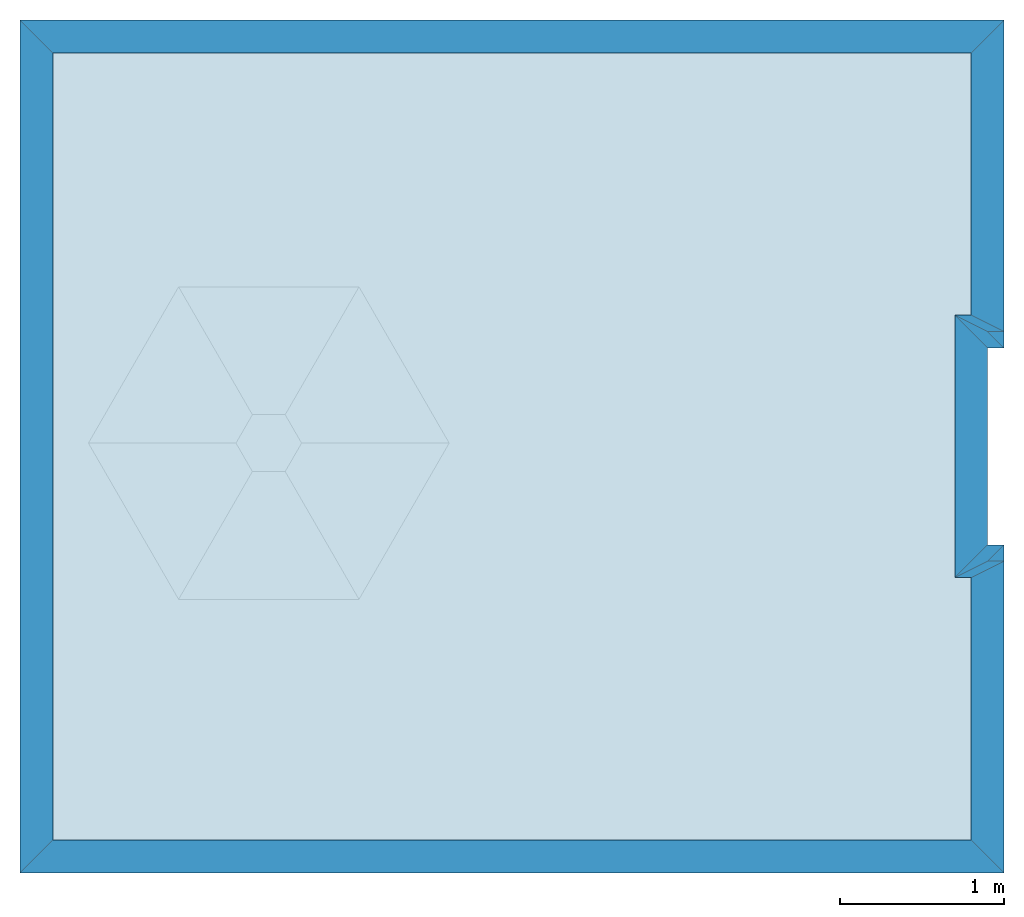
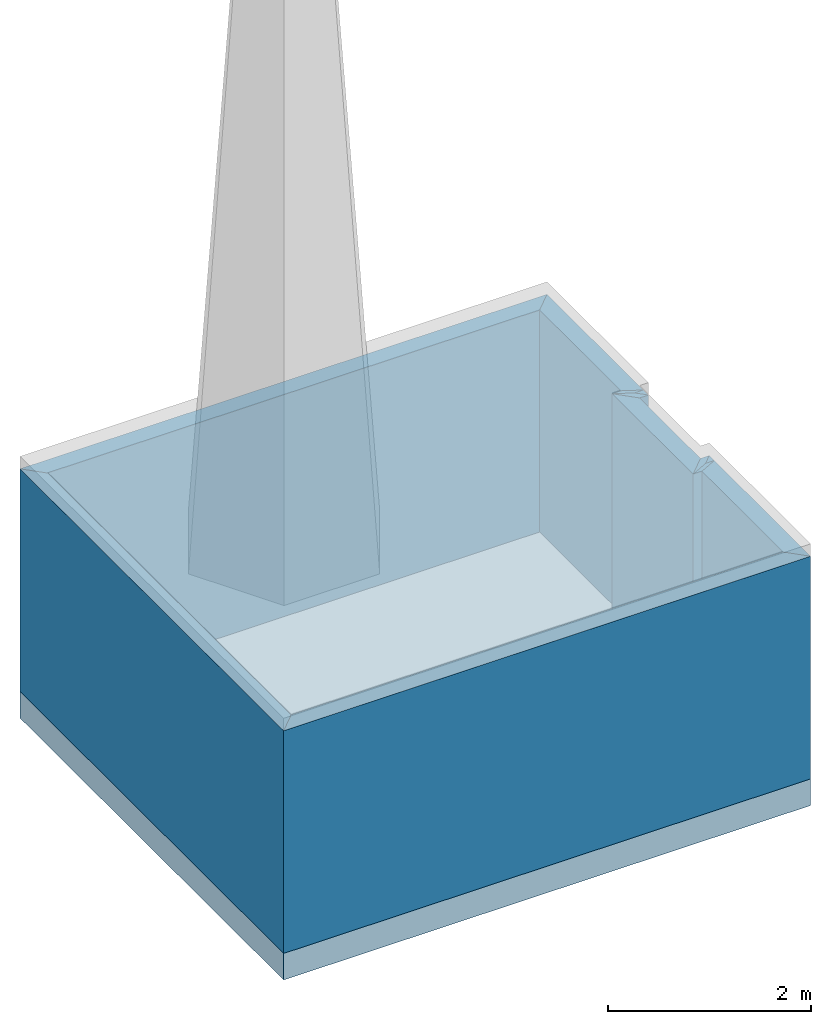
# One storey, part 1 of 2: 10 walls, 3 slabs.
"""IFC2X3 building model written with IfcOpenShell, lengths in metres."""

from ifc_helpers import new_model, entity, si_unit, converted_unit, derived_unit, frame, origin_with_axes, place, context, project, spatial, polyline, outline, extrude, material, layer, layer_set, layer_usage, element, save


model = new_model("IFC2X3")

# Units and contexts
context_of_model_1 = context(None, 3, world=origin_with_axes())
context_of_model_2 = context(None, 3, world=origin_with_axes())
context_of_model_3 = context(None, 2, world=origin_with_axes())
context_of_model_4 = context(None, 3, world=origin_with_axes())
ifc_project = project(units=[si_unit("LENGTHUNIT", "METRE"), si_unit("AREAUNIT", "SQUARE_METRE"), si_unit("ELECTRICCURRENTUNIT", "AMPERE"), si_unit("ELECTRICVOLTAGEUNIT", "VOLT"), si_unit("ELECTRICRESISTANCEUNIT", "OHM"), si_unit("POWERUNIT", "WATT"), si_unit("MASSUNIT", "GRAM"), si_unit("SOLIDANGLEUNIT", "STERADIAN"), si_unit("THERMODYNAMICTEMPERATUREUNIT", "KELVIN"), si_unit("PRESSUREUNIT", "PASCAL"), si_unit("LUMINOUSFLUXUNIT", "LUMEN"), si_unit("ILLUMINANCEUNIT", "LUX"), si_unit("FREQUENCYUNIT", "HERTZ"), si_unit("VOLUMEUNIT", "CUBIC_METRE"), si_unit("TIMEUNIT", "SECOND"), derived_unit("VOLUMETRICFLOWRATEUNIT", [(si_unit("TIMEUNIT", "SECOND"), -1), (si_unit("VOLUMEUNIT", "CUBIC_METRE"), 1)]), derived_unit("THERMALTRANSMITTANCEUNIT", [(si_unit("AREAUNIT", "SQUARE_METRE"), -1), (si_unit("THERMODYNAMICTEMPERATUREUNIT", "KELVIN"), -1), (si_unit("POWERUNIT", "WATT"), 1)]), converted_unit("PLANEANGLEUNIT", "DEGREE", entity("IfcPlaneAngleMeasure", 57.29577951308232), si_unit("PLANEANGLEUNIT", "RADIAN"), dimensions=[0, 0, 0, 0, 0, 0, 0])], contexts=[context_of_model_1, context_of_model_2, context_of_model_3, context_of_model_4])

# Site, building, storey
site = spatial("IfcSite", under=ifc_project, CompositionType="ELEMENT")
building_placement = place(None, origin_with_axes())
building = spatial("IfcBuilding", under=site, at=building_placement, Name="Tower", CompositionType="ELEMENT")
storey_placement = place(building_placement, frame((0.0, 0.0, 130.2800001573563), z_axis=(0.0, 0.0, 1.0), x_axis=(1.0, 0.0, 0.0)))
storey = spatial("IfcBuildingStorey", under=building, at=storey_placement, Name="Top level", CompositionType="ELEMENT", Elevation=130.2800001573563)

# Slabs
ifc_material_1 = material()
ifc_layer_1 = layer(ifc_material_1, 0.3199999928474426, ventilated=False)
ifc_layer_set_1 = layer_set([ifc_layer_1])
ifc_layer_usage_1 = layer_usage(ifc_layer_set_1, "AXIS2", "POSITIVE", 0.0)
slab_1_placement = place(storey_placement, frame((-5.900000095367432, 1.400000095367432, 0.0), z_axis=(0.0, 0.0, 1.0), x_axis=(1.0, 0.0, 0.0)))
element("IfcSlab", 1, at=slab_1_placement, inside=storey, material=ifc_layer_usage_1, PredefinedType="FLOOR", context=context_of_model_1, shape_type="SweptSolid", body=[
    extrude(outline(polyline([(0.0, 0.0), (6.000000096857548, 0.0), (6.000000007450581, 2.0), (5.900000095367441, 2.0), (5.900000042913781, 3.199999809265137), (6.000000096857548, 3.199999809265137), (6.000000007450581, 5.200000286102295), (0.0, 5.200000762939453), (0.0, 0.0)])), origin_with_axes(), (0.0, 0.0, -1.0), 0.3199999928474426),
])
slab_2_placement = place(storey_placement, frame((-5.700000286102295, 1.600000143051148, 0.0), z_axis=(0.0, 0.0, 1.0), x_axis=(1.0, 0.0, 0.0)))
element("IfcSlab", 2, at=slab_2_placement, inside=storey, material=ifc_layer_usage_1, PredefinedType="FLOOR", context=context_of_model_1, shape_type="SweptSolid", body=[
    extrude(outline(polyline([(0.0, 0.0), (5.600000277161598, 0.0), (5.600000202655792, 1.599999904632568), (5.500000298023224, 1.599999904632568), (5.500000208616257, 3.199999570846558), (5.600000277161598, 3.199999570846558), (5.600000202655792, 4.800000429153442), (0.0, 4.800000905990601), (0.0, 0.0)])), origin_with_axes(), (0.0, 0.0, 1.0), 0.01),
])
ifc_material_2 = material(Name="Layer")
ifc_layer_2 = layer(ifc_material_2, 0.0, ventilated=False)
ifc_layer_set_2 = layer_set([ifc_layer_2], Name="ML-0.000")
ifc_layer_usage_2 = layer_usage(ifc_layer_set_2, "AXIS2", "POSITIVE", 0.0)
slab_3_placement = place(storey_placement, frame((-5.700000286102295, 1.600000143051148, 2.680000066757202), z_axis=(0.0, 0.0, 1.0), x_axis=(1.0, 0.0, 0.0)))
element("IfcSlab", 3, at=slab_3_placement, inside=storey, material=ifc_layer_usage_2, PredefinedType="ROOF", context=context_of_model_1, shape_type="SweptSolid", body=[
    extrude(outline(polyline([(0.0, 0.0), (5.600000277161598, 0.0), (5.600000202655792, 1.599999904632568), (5.500000298023224, 1.599999904632568), (5.500000208616257, 3.199999570846558), (5.600000277161598, 3.199999570846558), (5.600000202655792, 4.800000429153442), (0.0, 4.800000905990601), (0.0, 0.0)])), origin_with_axes(), (0.0, 0.0, 1.0), 0.01),
])

# Walls
ifc_material_3 = material(Name="Layer-Yttervegg 20.0cm")
ifc_layer_3 = layer(ifc_material_3, 0.2000000029802322, ventilated=False)
ifc_layer_set_3 = layer_set([ifc_layer_3], Name="ML-Yttervegg 20.0cm - 0.200")
ifc_layer_usage_3 = layer_usage(ifc_layer_set_3, "AXIS2", "POSITIVE", 0.0)
wall_1_placement = place(storey_placement, frame((0.09999991208314896, 3.400000095367432, 0.0), z_axis=(0.0, 0.0, 1.0), x_axis=(-1.0, -8.742277657347586e-08, 0.0)))
element("IfcWallStandardCase", 4, at=wall_1_placement, inside=storey, material=ifc_layer_usage_3, Name="Yttervegg 20.0cm", context=context_of_model_1, shape_type="SweptSolid", body=[
    extrude(outline(polyline([(0.0, 0.0), (0.09999991208313981, 0.0), (0.2999999299645421, 0.2000000476837162), (0.1999999880790707, 0.2000000476837158), (0.0, 0.0)])), frame((0.0, 0.0, 0.0), z_axis=(0.0, 0.0, 1.0), x_axis=(0.9999999999999962, -8.742278149038844e-08, 0.0)), (0.0, 0.0, 1.0), 2.68),
])
wall_2_placement = place(storey_placement, frame((-5.245365031214533e-08, 4.599999904632568, 0.0), z_axis=(0.0, 0.0, 1.0), x_axis=(1.0, 0.0, 0.0)))
element("IfcWallStandardCase", 5, at=wall_2_placement, inside=storey, material=ifc_layer_usage_3, Name="Yttervegg 20.0cm", context=context_of_model_1, shape_type="SweptSolid", body=[
    extrude(outline(polyline([(0.0, 0.0), (0.1000000539437664, 0.0), (-0.0999999564870464, 0.1999998092651367), (-0.2000000250323879, 0.1999998092651367), (0.0, 0.0)])), origin_with_axes(), (0.0, 0.0, 1.0), 2.68),
])
wall_3_placement = place(storey_placement, frame((-5.900000095367432, 1.400000095367432, 0.0), z_axis=(0.0, 0.0, 1.0), x_axis=(1.0, 0.0, 0.0)))
element("IfcWallStandardCase", 6, at=wall_3_placement, inside=storey, material=ifc_layer_usage_3, Name="Yttervegg 20.0cm", context=context_of_model_1, shape_type="SweptSolid", body=[
    extrude(outline(polyline([(0.0, 0.0), (6.000000096857548, 0.0), (5.800000086426735, 0.2000000476837158), (0.1999998092651367, 0.2000000476837158), (0.0, 0.0)])), origin_with_axes(), (0.0, 0.0, 1.0), 2.68),
])
wall_4_placement = place(storey_placement, frame((0.1000000014901161, 1.400000095367432, 0.0), z_axis=(0.0, 0.0, 1.0), x_axis=(-4.371138828673793e-08, 1.0, 0.0)))
element("IfcWallStandardCase", 7, at=wall_4_placement, inside=storey, material=ifc_layer_usage_3, Name="Yttervegg 20.0cm", context=context_of_model_1, shape_type="SweptSolid", body=[
    extrude(outline(polyline([(0.0, 0.0), (2.000000000000002, 0.0), (1.799999961256983, 0.2000000044703503), (0.2000000566244128, 0.2000000014901138), (0.0, 0.0)])), frame((0.0, 0.0, 0.0), z_axis=(0.0, 0.0, 1.0), x_axis=(1.0, 9.920935808982448e-10, 0.0)), (0.0, 0.0, 1.0), 2.68),
])
ifc_material_4 = material()
ifc_layer_4 = layer(ifc_material_4, 0.1, ventilated=False)
ifc_layer_set_4 = layer_set([ifc_layer_4])
ifc_layer_usage_4 = layer_usage(ifc_layer_set_4, "AXIS2", "POSITIVE", 0.0)
wall_5_placement = place(storey_placement, frame((0.09999991953372955, 3.299999952316284, 0.0), z_axis=(0.0, 0.0, 1.0), x_axis=(-1.0, -8.742277657347586e-08, 0.0)))
element("IfcWallStandardCase", 8, at=wall_5_placement, inside=storey, material=ifc_layer_usage_4, context=context_of_model_1, shape_type="SweptSolid", body=[
    extrude(outline(polyline([(0.0, 0.0), (0.09999991208314898, 0.0), (0.2999999076128005, 0.09999990463256865), (0.2000000029802322, 0.09999990463256886), (0.0, 0.0)])), frame((0.0, 0.0, 0.0), z_axis=(0.0, 0.0, 1.0), x_axis=(0.9999999999999961, -8.742278149038043e-08, 0.0)), (0.0, 0.0, 1.0), 2.68),
])
wall_6_placement = place(storey_placement, frame((9.145462165349727e-15, 3.400000095367432, 0.0), z_axis=(0.0, 0.0, 1.0), x_axis=(-4.371138828673793e-08, 1.0, 0.0)))
element("IfcWallStandardCase", 9, at=wall_6_placement, inside=storey, material=ifc_layer_usage_3, Name="Yttervegg 20.0cm", context=context_of_model_1, shape_type="SweptSolid", body=[
    extrude(outline(polyline([(0.0, 0.0), (1.199999809265139, 0.0), (1.399999627272554, 0.2000000162901181), (-0.2000000389414378, 0.1999999968213601), (0.0, 0.0)])), frame((0.0, 0.0, 0.0), z_axis=(0.0, 0.0, 1.0), x_axis=(1.0, -1.727845578380962e-16, 0.0)), (0.0, 0.0, 1.0), 2.68),
])
wall_7_placement = place(storey_placement, frame((-7.450580596923828e-08, 4.699999809265137, 0.0), z_axis=(0.0, 0.0, 1.0), x_axis=(1.0, 0.0, 0.0)))
element("IfcWallStandardCase", 10, at=wall_7_placement, inside=storey, material=ifc_layer_usage_4, context=context_of_model_1, shape_type="SweptSolid", body=[
    extrude(outline(polyline([(0.0, 0.0), (0.1000000685453415, 0.0), (-0.09999993443489075, 0.09999990463256836), (-0.2000000029802322, 0.09999990463256836), (0.0, 0.0)])), origin_with_axes(), (0.0, 0.0, 1.0), 2.68),
])
wall_8_placement = place(storey_placement, frame((0.1000000014901161, 4.599999904632568, 0.0), z_axis=(0.0, 0.0, 1.0), x_axis=(-4.371138828673793e-08, 1.0, 0.0)))
element("IfcWallStandardCase", 11, at=wall_8_placement, inside=storey, material=ifc_layer_usage_3, Name="Yttervegg 20.0cm", context=context_of_model_1, shape_type="SweptSolid", body=[
    extrude(outline(polyline([(0.0, 0.0), (2.00000047683716, 0.0), (1.800000676512718, 0.2000000044703375), (0.1999998182058313, 0.2000000014901266), (0.0, 0.0)])), frame((0.0, 0.0, 0.0), z_axis=(0.0, 0.0, 1.0), x_axis=(1.0, 9.920829221486003e-10, 0.0)), (0.0, 0.0, 1.0), 2.68),
])
wall_9_placement = place(storey_placement, frame((0.09999991208314896, 6.600000381469727, 0.0), z_axis=(0.0, 0.0, 1.0), x_axis=(-1.0, 1.509958025280866e-07, 0.0)))
element("IfcWallStandardCase", 12, at=wall_9_placement, inside=storey, material=ifc_layer_usage_3, Name="Yttervegg 20.0cm", context=context_of_model_1, shape_type="SweptSolid", body=[
    extrude(outline(polyline([(0.0, 0.0), (6.0000000074506, 0.0), (5.800000182290908, 0.1999997933705797), (0.1999999796350943, 0.1999998251597078), (0.0, 0.0)])), frame((0.0, 0.0, 0.0), z_axis=(0.0, 0.0, 1.0), x_axis=(0.9999999999999973, 7.152293948209681e-08, 0.0)), (0.0, 0.0, 1.0), 2.68),
])
wall_10_placement = place(storey_placement, frame((-5.900000095367432, 6.600000858306885, 0.0), z_axis=(0.0, 0.0, 1.0), x_axis=(-4.371138828673793e-08, -1.0, 0.0)))
element("IfcWallStandardCase", 13, at=wall_10_placement, inside=storey, material=ifc_layer_usage_3, Name="Yttervegg 20.0cm", context=context_of_model_1, shape_type="SweptSolid", body=[
    extrude(outline(polyline([(0.0, 0.0), (5.200000762939454, 2.646977960169689e-23), (5.000000715255738, 0.1999998092651363), (0.1999998092651375, 0.1999998092651364), (0.0, 0.0)])), frame((0.0, 0.0, 0.0), z_axis=(0.0, 0.0, 1.0), x_axis=(0.999999999999999, 4.371138996952891e-08, 0.0)), (0.0, 0.0, 1.0), 2.68),
])

save(model, "model.ifc")
